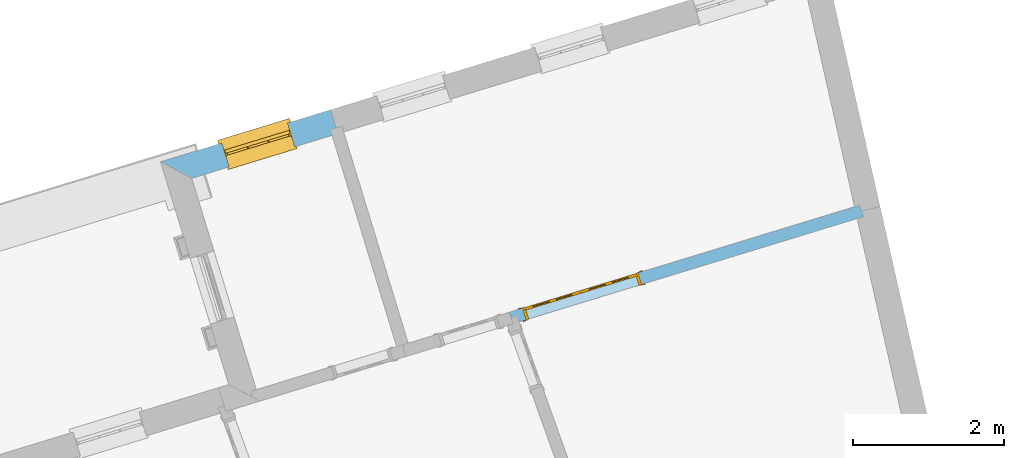
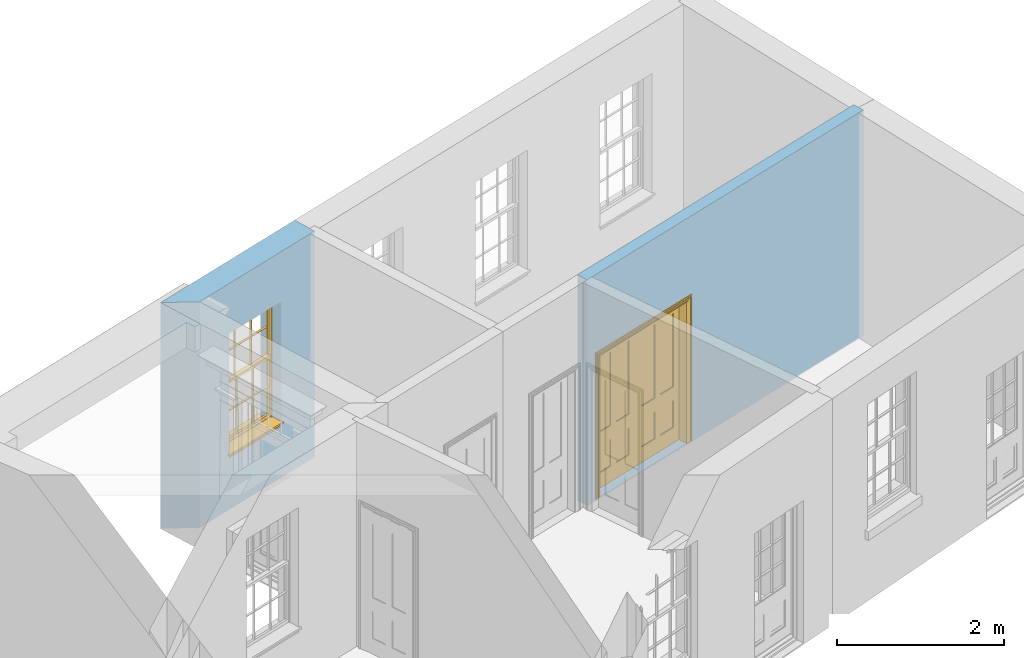
# One storey, part 8 of 10: 1 door, 1 window, 2 openings, plus 2 elements that do not belong to this part.
"""IFC2X3 building model written with IfcOpenShell, lengths in metres."""

from ifc_helpers import new_model, si_unit, frame, origin, place, context, subcontext, project, spatial, polyline, outline, extrude, faceted_brep, material, layer, layer_set, layer_usage, element, fill, save


model = new_model("IFC2X3")

# Units and contexts
model_context = context("Model", 3, world=origin())
body_context = subcontext(model_context, "Body", "Model", "MODEL_VIEW")
ifc_project = project(units=[si_unit("PLANEANGLEUNIT", "RADIAN"), si_unit("MASSUNIT", "GRAM", prefix="KILO"), si_unit("FORCEUNIT", "NEWTON", prefix="KILO"), si_unit("LENGTHUNIT", "METRE")], contexts=[model_context])

# Site, building, storey
site_placement = place(None, origin())
site = spatial("IfcSite", under=ifc_project, at=site_placement, CompositionType="ELEMENT")
building_placement = place(None, origin())
building = spatial("IfcBuilding", under=site, at=building_placement, Name="Building plot-9", CompositionType="ELEMENT")
storey_placement = place(None, frame((0.0, 0.0, 1.0)))
storey = spatial("IfcBuildingStorey", under=building, at=storey_placement, Name="Floor 0", CompositionType="ELEMENT", Elevation=1.0)

# Wall, opening, window
ifc_material_1 = material(Name="Masonry")
ifc_layer_1 = layer(ifc_material_1, 0.33, ventilated=False)
ifc_layer_set_1 = layer_set([ifc_layer_1], Name="My Wall")
ifc_layer_usage_1 = layer_usage(ifc_layer_set_1, "AXIS2", "NEGATIVE", 0.08)
wall_1_placement = place(storey_placement, origin())
wall_1 = element("IfcWallStandardCase", 1, at=wall_1_placement, inside=storey, material=ifc_layer_usage_1, Name="exterior", context=body_context, shape_type="SweptSolid", body=[
    extrude(outline(polyline([(34.0704461659636, 21.7289389517045), (33.9739704454548, 22.0445216434864), (31.7285492158165, 21.3580814912976), (32.1406076281071, 21.1389745200244), (34.0704461659636, 21.7289389517045)])), origin(), (0.0, 0.0, 1.0), 3.3),
])
opening_1_placement = place(storey_placement, frame((0.0, 0.0, 0.75)))
opening_1 = element("IfcOpeningElement", 2, at=opening_1_placement, cuts=wall_1, Name="Opening", ObjectType="Opening", context=body_context, shape_type="SweptSolid", body=[
    extrude(outline(polyline([(33.4059203192221, 21.8708649549528), (32.5356771388537, 21.6048258468833), (32.6321528593624, 21.2892431551014), (33.5023960397308, 21.5552822631709), (33.4059203192221, 21.8708649549528)])), origin(), (0.0, 0.0, 1.0), 1.82),
])
window_placement = place(storey_placement, frame((33.4790079862741, 21.6317871581483, 0.75), z_axis=(0.0, 0.0, 1.0), x_axis=(-0.870243180368334, -0.266039108069478, 0.0)))
window = element("IfcWindow", 3, at=window_placement, inside=storey, Name="circulation street window", OverallHeight=1.82, OverallWidth=0.91, context=body_context, shape_type="Brep", held_by="IfcProductRepresentation", body=[
    faceted_brep([(0.033125, -0.105, 0.975209), (0.01, -0.105, 0.975209), (0.033125, -0.105, 1.376042), (0.876875, -0.105, 0.975209), (0.876875, -0.105, 1.376042), (0.9, -0.105, 0.975209), (0.876875, -0.105, 1.386042), (0.876875, -0.105, 1.786875), (0.9, -0.105, 1.81), (0.033125, -0.105, 1.786875), (0.033125, -0.105, 1.386042), (0.01, -0.105, 1.81), (0.876875, -0.135, 1.376042), (0.876875, -0.135, 0.975209), (0.9, -0.135, 0.937083), (0.033125, -0.135, 1.786875), (0.01, -0.135, 1.81), (0.033125, -0.135, 1.386042), (0.01, -0.135, 0.937083), (0.033125, -0.135, 0.975209), (0.033125, -0.135, 1.376042), (0.876875, -0.135, 1.786875), (0.876875, -0.135, 1.386042), (0.9, -0.135, 1.81), (0.033125, -0.105, 0.937083), (0.01, -0.105, 0.937083), (0.033125, -0.105, 0.53625), (0.876875, -0.105, 0.937083), (0.876875, -0.105, 0.53625), (0.9, -0.105, 0.937083), (0.876875, -0.105, 0.52625), (0.876875, -0.105, 0.125417), (0.9, -0.105, 0.077167), (0.033125, -0.105, 0.125417), (0.033125, -0.105, 0.52625), (0.01, -0.105, 0.077167), (-0.0425, -0.25, 0.01), (-0.0425, -0.3, 0.001667), (0.0, -0.25, 0.01), (0.9525, -0.25, 0.01), (0.91, -0.25, 0.01), (0.9525, -0.3, 0.001667), (-0.02, 0.08, 0.077167), (0.0, 0.08, 0.077167), (-0.02, 0.11, 0.077167), (0.0, -0.06, 0.077167), (0.01, -0.06, 0.077167), (0.91, -0.06, 0.077167), (0.91, 0.08, 0.077167), (0.9, -0.06, 0.077167), (0.93, 0.08, 0.077167), (0.93, 0.11, 0.077167), (0.01, -0.075, 0.975209), (0.9, -0.075, 0.975209), (0.876875, -0.075, 0.125417), (0.876875, -0.075, 0.52625), (0.9, -0.075, 0.077167), (0.876875, -0.075, 0.53625), (0.876875, -0.075, 0.937083), (0.033125, -0.075, 0.125417), (0.01, -0.075, 0.077167), (0.033125, -0.075, 0.52625), (0.033125, -0.075, 0.937083), (0.033125, -0.075, 0.53625), (-0.02, 0.08, 0.052167), (-0.02, 0.11, 0.052167), (0.93, 0.11, 0.052167), (0.93, 0.08, 0.052167), (0.91, 0.08, 0.052167), (0.0, 0.08, 0.052167), (0.91, -0.15, 0.026667), (0.0, -0.15, 0.026667), (-0.0425, -0.3, -0.123333), (0.9525, -0.3, -0.123333), (-0.0425, -0.25, -0.123333), (0.9525, -0.25, -0.123333), (0.01, -0.06, 1.81), (0.9, -0.06, 1.81), (0.0, -0.06, 1.82), (0.91, -0.06, 1.82), (0.01, -0.15, 0.077167), (0.9, -0.15, 0.077167), (0.592292, -0.105, 0.125417), (0.592292, -0.075, 0.125417), (0.317708, -0.075, 0.125417), (0.317708, -0.105, 0.125417), (0.592292, -0.105, 0.53625), (0.317708, -0.105, 0.53625), (0.317708, -0.105, 0.52625), (0.592292, -0.105, 0.52625), (0.592292, -0.075, 0.53625), (0.317708, -0.075, 0.53625), (0.592292, -0.135, 1.386042), (0.592292, -0.105, 1.386042), (0.317708, -0.105, 1.386042), (0.317708, -0.135, 1.386042), (0.317708, -0.135, 1.376042), (0.592292, -0.135, 1.376042), (0.317708, -0.105, 1.376042), (0.592292, -0.105, 1.376042), (0.602292, -0.135, 1.376042), (0.592292, -0.135, 0.975209), (0.602292, -0.135, 0.975209), (0.602292, -0.105, 0.975209), (0.592292, -0.105, 0.975209), (0.602292, -0.105, 1.376042), (0.602292, -0.075, 0.53625), (0.602292, -0.105, 0.53625), (0.317708, -0.075, 0.52625), (0.307708, -0.075, 0.125417), (0.307708, -0.075, 0.52625), (0.602292, -0.075, 0.52625), (0.602292, -0.075, 0.125417), (0.592292, -0.075, 0.52625), (0.307708, -0.075, 0.53625), (0.317708, -0.075, 0.937083), (0.307708, -0.075, 0.937083), (0.602292, -0.075, 0.937083), (0.592292, -0.075, 0.937083), (0.307708, -0.105, 0.52625), (0.307708, -0.105, 0.125417), (0.307708, -0.105, 0.53625), (0.307708, -0.105, 0.937083), (0.592292, -0.105, 0.937083), (0.317708, -0.105, 0.937083), (0.602292, -0.105, 0.937083), (0.602292, -0.105, 0.52625), (0.602292, -0.105, 0.125417), (0.307708, -0.135, 1.386042), (0.307708, -0.135, 1.376042), (0.307708, -0.135, 0.975209), (0.317708, -0.135, 0.975209), (0.317708, -0.135, 1.786875), (0.307708, -0.135, 1.786875), (0.602292, -0.135, 1.786875), (0.592292, -0.135, 1.786875), (0.602292, -0.135, 1.386042), (0.602292, -0.105, 1.386042), (0.307708, -0.105, 1.386042), (0.307708, -0.105, 1.786875), (0.317708, -0.105, 1.786875), (0.592292, -0.105, 1.786875), (0.602292, -0.105, 1.786875), (0.307708, -0.105, 1.376042), (0.317708, -0.105, 0.975209), (0.307708, -0.105, 0.975209), (0.91, -0.15, 1.82), (0.9, -0.15, 1.81), (0.01, -0.15, 1.81), (0.0, -0.15, 1.82), (0.91, -0.25, 0.0), (0.0, -0.25, 0.0), (0.91, 0.08, 0.0), (0.0, 0.08, 0.0)], [[[0, 1, 2]], [[3, 4, 5]], [[6, 7, 8]], [[9, 10, 11]], [[12, 13, 14]], [[15, 16, 17]], [[18, 19, 20]], [[21, 22, 23]], [[24, 25, 26]], [[27, 28, 29]], [[30, 31, 32]], [[33, 34, 35]], [[14, 27, 29]], [[25, 24, 18]], [[36, 37, 38]], [[39, 40, 41]], [[42, 43, 44]], [[45, 46, 43]], [[47, 48, 49]], [[50, 51, 48]], [[1, 0, 52]], [[5, 53, 3]], [[54, 55, 56]], [[57, 58, 53]], [[59, 60, 61]], [[62, 63, 52]], [[48, 43, 46, 49]], [[51, 44, 43, 48]], [[64, 42, 44, 65]], [[65, 44, 51, 66]], [[66, 51, 50, 67]], [[65, 66, 68, 69]], [[60, 56, 49, 46]], [[70, 71, 38, 40]], [[37, 41, 40, 38]], [[37, 72, 73, 41]], [[74, 75, 73, 72]], [[8, 11, 76, 77]], [[76, 78, 79, 77]], [[32, 35, 80, 81]], [[81, 80, 71, 70]], [[82, 83, 84, 85]], [[86, 87, 88, 89]], [[86, 90, 91, 87]], [[92, 93, 94, 95]], [[92, 95, 96, 97]], [[96, 98, 99, 97]], [[100, 97, 101, 102]], [[103, 104, 99, 105]], [[97, 99, 104, 101]], [[102, 103, 105, 100]], [[28, 57, 106, 107]], [[108, 84, 109, 110]], [[111, 112, 83, 113]], [[114, 110, 61, 63]], [[90, 113, 108, 91]], [[115, 91, 114, 116]], [[117, 106, 90, 118]], [[111, 106, 57, 55]], [[119, 110, 109, 120]], [[34, 61, 110, 119]], [[89, 113, 83, 82]], [[88, 108, 113, 89]], [[85, 84, 108, 88]], [[121, 114, 63, 26]], [[122, 116, 114, 121]], [[123, 118, 90, 86]], [[87, 91, 115, 124]], [[107, 106, 117, 125]], [[126, 111, 55, 30]], [[127, 112, 111, 126]], [[126, 30, 28, 107]], [[88, 119, 120, 85]], [[126, 89, 82, 127]], [[125, 123, 86, 107]], [[121, 26, 34, 119]], [[124, 122, 121, 87]], [[128, 17, 20, 129]], [[96, 129, 130, 131]], [[132, 133, 128, 95]], [[134, 135, 92, 136]], [[100, 12, 22, 136]], [[137, 6, 4, 105]], [[94, 138, 139, 140]], [[137, 93, 141, 142]], [[99, 98, 94, 93]], [[143, 2, 10, 138]], [[144, 145, 143, 98]], [[129, 143, 145, 130]], [[20, 2, 143, 129]], [[131, 144, 98, 96]], [[128, 138, 10, 17]], [[133, 139, 138, 128]], [[135, 141, 93, 92]], [[95, 94, 140, 132]], [[22, 6, 137, 136]], [[136, 137, 142, 134]], [[100, 105, 4, 12]], [[107, 86, 89, 126]], [[106, 111, 113, 90]], [[91, 108, 110, 114]], [[87, 121, 119, 88]], [[97, 100, 136, 92]], [[129, 96, 95, 128]], [[98, 143, 138, 94]], [[105, 99, 93, 137]], [[131, 101, 104, 144]], [[124, 115, 118, 123]], [[132, 140, 141, 135]], [[120, 109, 59, 33]], [[15, 9, 139, 133]], [[134, 142, 7, 21]], [[31, 54, 112, 127]], [[36, 74, 72, 37]], [[39, 41, 73, 75]], [[18, 14, 101, 131]], [[23, 16, 132, 135]], [[83, 56, 60, 84]], [[52, 53, 118, 115]], [[53, 52, 144, 104]], [[11, 8, 141, 140]], [[14, 18, 124, 123]], [[2, 1, 11, 10]], [[8, 5, 4, 6]], [[57, 53, 56, 55]], [[60, 52, 63, 61]], [[26, 25, 35, 34]], [[32, 29, 28, 30]], [[14, 23, 22, 12]], [[18, 20, 17, 16]], [[19, 0, 2, 20]], [[17, 10, 9, 15]], [[12, 4, 3, 13]], [[21, 7, 6, 22]], [[27, 58, 57, 28]], [[30, 55, 54, 31]], [[33, 59, 61, 34]], [[26, 63, 62, 24]], [[5, 8, 77, 53]], [[76, 11, 1, 52]], [[46, 45, 78, 76]], [[49, 77, 79, 47]], [[70, 146, 147, 81]], [[71, 80, 148, 149]], [[19, 130, 145, 0]], [[102, 13, 3, 103]], [[116, 122, 24, 62]], [[29, 32, 81, 14]], [[80, 35, 25, 18]], [[60, 46, 76, 52]], [[77, 49, 56, 53]], [[23, 14, 81, 147]], [[16, 148, 80, 18]], [[35, 85, 120]], [[120, 33, 35]], [[127, 82, 32]], [[32, 31, 127]], [[32, 82, 85, 35]], [[102, 101, 14]], [[14, 13, 102]], [[18, 131, 130]], [[130, 19, 18]], [[134, 21, 23]], [[23, 135, 134]], [[16, 15, 133]], [[133, 132, 16]], [[11, 140, 139]], [[139, 9, 11]], [[142, 141, 8]], [[8, 7, 142]], [[23, 147, 148, 16]], [[146, 149, 148, 147]], [[52, 115, 116]], [[116, 62, 52]], [[118, 53, 117]], [[58, 117, 53]], [[27, 125, 117, 58]], [[56, 83, 112]], [[112, 54, 56]], [[109, 84, 60]], [[60, 59, 109]], [[125, 27, 14]], [[14, 123, 125]], [[122, 124, 18]], [[18, 24, 122]], [[145, 144, 52]], [[52, 0, 145]], [[103, 3, 53]], [[53, 104, 103]], [[79, 78, 149, 146]], [[78, 45, 71, 149]], [[146, 70, 47, 79]], [[150, 75, 74, 151]], [[68, 66, 67]], [[48, 68, 67, 50]], [[69, 64, 65]], [[42, 64, 69, 43]], [[69, 68, 152, 153]], [[70, 68, 48, 47]], [[150, 152, 68, 70]], [[43, 69, 71, 45]], [[69, 153, 151, 71]], [[152, 150, 151, 153]], [[38, 151, 74, 36]], [[71, 151, 38]], [[39, 75, 150, 40]], [[40, 150, 70]]]),
])
fill(opening_1, window)

# Wall, opening, door
ifc_material_2 = material(Name="Masonry")
ifc_layer_2 = layer(ifc_material_2, 0.16, ventilated=False)
ifc_layer_set_2 = layer_set([ifc_layer_2], Name="My Wall")
ifc_layer_usage_2 = layer_usage(ifc_layer_set_2, "AXIS2", "NEGATIVE", 0.08)
wall_2_placement = place(storey_placement, origin())
wall_2 = element("IfcWallStandardCase", 4, at=wall_2_placement, inside=storey, material=ifc_layer_usage_2, Name="interior", context=body_context, shape_type="SweptSolid", body=[
    extrude(outline(polyline([(36.3355604715048, 19.3699546633605), (36.3823365784182, 19.2169448734057), (41.0127738898931, 20.6325002493123), (40.9659977829797, 20.7855100392671), (36.3355604715048, 19.3699546633605)])), origin(), (0.0, 0.0, 1.0), 3.3),
])
opening_2_placement = place(storey_placement, frame((0.0, 0.0, 0.02)))
opening_2 = element("IfcOpeningElement", 5, at=opening_2_placement, cuts=wall_2, Name="Opening", ObjectType="Opening", context=body_context, shape_type="SweptSolid", body=[
    extrude(outline(polyline([(36.5544725921174, 19.2695679936831), (38.0845704916661, 19.7373290628163), (38.0377943847528, 19.8903388527712), (36.5076964852041, 19.422577783638), (36.5544725921174, 19.2695679936831)])), origin(), (0.0, 0.0, 1.0), 2.1),
])
door_placement = place(storey_placement, frame((36.5310845386607, 19.3460728886606, 0.02), z_axis=(0.0, 0.0, 1.0), x_axis=(1.53009789954872, 0.467761069133164, 0.0)))
door = element("IfcDoor", 6, at=door_placement, inside=storey, Name="kitchen living inside door", OverallHeight=2.1, OverallWidth=1.6, context=body_context, shape_type="Brep", held_by="IfcProductRepresentation", body=[
    faceted_brep([(0.14, 0.057, 1.895), (0.14, 0.057, 0.82), (0.363, 0.057, 0.82), (0.363, 0.057, 1.895), (0.14, 0.042, 1.895), (0.14, 0.042, 0.82), (0.363, 0.042, 0.82), (0.363, 0.042, 1.895), (0.027, 0.042, 1.895), (0.027, 0.042, 0.82), (0.363, 0.042, 0.62), (0.14, 0.042, 0.62), (0.463, 0.042, 0.82), (0.463, 0.042, 1.895), (0.363, 0.042, 2.073), (0.14, 0.042, 2.073), (0.027, 0.042, 2.073), (0.027, 0.08, 1.895), (0.027, 0.08, 0.82), (0.027, 0.042, 0.62), (0.463, 0.042, 0.62), (0.14, 0.057, 0.62), (0.363, 0.057, 0.62), (0.463, 0.057, 0.82), (0.463, 0.057, 1.895), (0.463, 0.042, 2.073), (0.14, 0.08, 2.073), (0.363, 0.08, 2.073), (0.027, 0.08, 2.073), (0.14, 0.08, 1.895), (0.14, 0.08, 0.82), (0.027, 0.08, 0.62), (0.027, 0.042, 0.225), (0.14, 0.042, 0.225), (0.363, 0.042, 0.225), (0.463, 0.042, 0.225), (0.686, 0.042, 0.62), (0.686, 0.042, 0.82), (0.14, 0.057, 0.225), (0.363, 0.057, 0.225), (0.686, 0.057, 0.82), (0.686, 0.057, 1.895), (0.686, 0.042, 1.895), (0.686, 0.042, 2.073), (0.463, 0.08, 2.073), (0.363, 0.08, 1.895), (0.14, 0.065, 1.895), (0.14, 0.065, 0.82), (0.14, 0.08, 0.62), (0.027, 0.08, 0.225), (0.027, 0.042, 0.0), (0.14, 0.042, 0.0), (0.363, 0.042, 0.0), (0.463, 0.042, 0.0), (0.463, 0.057, 0.225), (0.463, 0.057, 0.62), (0.686, 0.057, 0.62), (0.799, 0.042, 0.62), (0.799, 0.042, 0.82), (0.799, 0.042, 1.895), (0.799, 0.042, 2.073), (0.686, 0.08, 2.073), (0.463, 0.08, 1.895), (0.363, 0.065, 1.895), (0.363, 0.065, 0.82), (0.363, 0.08, 0.82), (0.363, 0.08, 0.62), (0.14, 0.08, 0.225), (0.027, 0.08, 0.0), (0.14, 0.08, 0.0), (0.363, 0.08, 0.0), (0.463, 0.08, 0.0), (0.686, 0.042, 0.0), (0.686, 0.042, 0.225), (0.686, 0.057, 0.225), (0.799, 0.042, 0.225), (0.799, 0.08, 0.62), (0.799, 0.08, 0.82), (0.799, 0.08, 1.895), (0.799, 0.08, 2.073), (0.686, 0.08, 1.895), (0.463, 0.08, 0.82), (0.463, 0.08, 0.62), (0.363, 0.065, 0.62), (0.14, 0.065, 0.62), (0.14, 0.065, 0.225), (0.363, 0.08, 0.225), (0.463, 0.08, 0.225), (0.686, 0.08, 0.0), (0.799, 0.042, 0.0), (0.799, 0.08, 0.225), (0.686, 0.08, 0.62), (0.686, 0.08, 0.82), (0.686, 0.065, 1.895), (0.463, 0.065, 1.895), (0.463, 0.065, 0.82), (0.363, 0.065, 0.225), (0.686, 0.08, 0.225), (0.799, 0.08, 0.0), (0.686, 0.065, 0.82), (0.463, 0.065, 0.62), (0.463, 0.065, 0.225), (0.686, 0.065, 0.62), (0.686, 0.065, 0.225), (1.46, 0.08, 1.895), (1.237, 0.08, 1.895), (1.237, 0.08, 2.073), (1.46, 0.08, 2.073), (1.46, 0.065, 1.895), (1.237, 0.065, 1.895), (1.137, 0.08, 1.895), (1.137, 0.08, 2.073), (1.237, 0.042, 2.073), (1.46, 0.042, 2.073), (1.573, 0.08, 1.895), (1.573, 0.08, 2.073), (1.46, 0.08, 0.82), (1.46, 0.065, 0.82), (1.237, 0.065, 0.82), (1.237, 0.08, 0.82), (1.137, 0.08, 0.82), (0.914, 0.08, 2.073), (0.914, 0.08, 1.895), (1.137, 0.042, 2.073), (1.237, 0.042, 1.895), (1.46, 0.042, 1.895), (1.573, 0.042, 2.073), (1.573, 0.08, 0.82), (1.573, 0.042, 1.895), (1.237, 0.08, 0.62), (1.137, 0.08, 0.62), (1.137, 0.065, 0.82), (1.137, 0.065, 1.895), (0.914, 0.042, 2.073), (0.914, 0.065, 1.895), (0.801, 0.08, 2.073), (0.801, 0.08, 1.895), (1.137, 0.042, 1.895), (1.237, 0.057, 1.895), (1.46, 0.057, 1.895), (1.573, 0.042, 0.82), (1.573, 0.08, 0.62), (1.46, 0.08, 0.62), (1.237, 0.08, 0.225), (1.137, 0.08, 0.225), (0.914, 0.08, 0.82), (0.914, 0.08, 0.62), (0.914, 0.065, 0.82), (0.801, 0.042, 2.073), (0.914, 0.042, 1.895), (0.801, 0.08, 0.82), (0.801, 0.042, 1.895), (1.137, 0.042, 0.82), (1.237, 0.042, 0.82), (1.237, 0.057, 0.82), (1.46, 0.057, 0.82), (1.46, 0.042, 0.82), (1.573, 0.042, 0.62), (1.573, 0.08, 0.225), (1.46, 0.08, 0.225), (1.46, 0.065, 0.62), (1.237, 0.065, 0.62), (1.237, 0.08, 0.0), (1.137, 0.08, 0.0), (1.137, 0.065, 0.225), (1.137, 0.065, 0.62), (1.237, 0.065, 0.225), (0.914, 0.065, 0.62), (0.801, 0.08, 0.62), (0.914, 0.057, 1.895), (1.137, 0.057, 1.895), (0.801, 0.042, 0.82), (1.137, 0.042, 0.62), (1.237, 0.042, 0.62), (1.137, 0.057, 0.82), (1.46, 0.042, 0.62), (1.573, 0.042, 0.225), (1.573, 0.08, 0.0), (1.46, 0.08, 0.0), (1.46, 0.065, 0.225), (1.237, 0.042, 0.0), (1.137, 0.042, 0.0), (0.914, 0.08, 0.225), (0.914, 0.08, 0.0), (0.914, 0.065, 0.225), (0.801, 0.08, 0.225), (0.801, 0.042, 0.62), (0.914, 0.042, 0.82), (0.914, 0.057, 0.82), (1.137, 0.042, 0.225), (1.237, 0.042, 0.225), (0.914, 0.042, 0.62), (1.46, 0.042, 0.225), (1.573, 0.042, 0.0), (1.46, 0.042, 0.0), (0.914, 0.042, 0.0), (0.801, 0.08, 0.0), (0.801, 0.042, 0.225), (1.237, 0.057, 0.225), (1.237, 0.057, 0.62), (1.137, 0.057, 0.62), (1.137, 0.057, 0.225), (1.46, 0.057, 0.62), (0.914, 0.057, 0.62), (1.46, 0.057, 0.225), (0.914, 0.042, 0.225), (0.801, 0.042, 0.0), (0.914, 0.057, 0.225), (0.02, 0.085, 0.0), (0.005, 0.09, 0.0), (0.005, 0.09, 2.095), (0.02, 0.085, 2.08), (0.02, 0.08, 0.0), (0.0, 0.085, 0.0), (0.0, 0.085, 2.1), (1.595, 0.09, 2.095), (1.58, 0.085, 2.08), (0.02, 0.08, 2.08), (0.0, 0.08, 0.0), (-0.032, 0.095, 0.0), (-0.032, 0.095, 2.132), (1.6, 0.085, 2.1), (1.595, 0.09, 0.0), (1.58, 0.085, 0.0), (1.58, 0.08, 2.08), (0.025, 0.08, 0.0), (0.025, 0.08, 2.075), (-0.04, 0.09, 0.0), (0.025, 0.04, 0.0), (0.0, -0.08, 0.0), (-0.04, 0.09, 2.14), (1.632, 0.095, 2.132), (1.6, 0.085, 0.0), (1.58, 0.08, 0.0), (1.575, 0.08, 2.075), (0.025, 0.04, 2.075), (-0.06, 0.08, 0.0), (0.035, -0.08, 0.0), (0.0, -0.08, 2.1), (0.0, 0.08, 2.1), (-0.04, 0.095, 0.0), (-0.04, 0.095, 2.14), (1.64, 0.09, 2.14), (1.632, 0.095, 0.0), (1.6, 0.08, 0.0), (1.575, 0.08, 0.0), (1.575, 0.04, 2.075), (0.04, 0.04, 0.0), (0.04, 0.04, 2.06), (-0.06, 0.095, 0.0), (-0.06, 0.08, 2.16), (0.015, -0.085, 0.0), (0.04, -0.08, 0.0), (-0.045, -0.08, 2.145), (-0.045, -0.08, 0.0), (1.6, -0.08, 2.1), (1.6, 0.08, 2.1), (-0.06, 0.095, 2.16), (1.64, 0.095, 2.14), (1.64, 0.09, 0.0), (1.6, -0.08, 0.0), (1.575, 0.04, 0.0), (1.56, 0.04, 2.06), (0.04, -0.08, 2.06), (1.66, 0.08, 2.16), (-0.017, -0.095, 0.0), (-0.025, -0.09, 0.0), (0.02, -0.09, 0.0), (0.035, -0.085, 0.0), (0.035, -0.08, 2.065), (1.645, -0.08, 2.145), (-0.045, -0.095, 2.145), (-0.045, -0.095, 0.0), (1.66, 0.095, 2.16), (1.64, 0.095, 0.0), (1.66, 0.08, 0.0), (1.565, -0.08, 0.0), (1.56, 0.04, 0.0), (1.56, -0.08, 2.06), (-0.017, -0.095, 2.117), (-0.025, -0.09, 2.125), (0.015, -0.085, 2.085), (0.02, -0.09, 2.08), (0.035, -0.085, 2.065), (1.565, -0.08, 2.065), (1.645, -0.08, 0.0), (1.645, -0.095, 2.145), (-0.025, -0.095, 0.0), (1.66, 0.095, 0.0), (1.585, -0.085, 0.0), (1.56, -0.08, 0.0), (1.617, -0.095, 2.117), (1.625, -0.09, 2.125), (-0.025, -0.095, 2.125), (1.585, -0.085, 2.085), (1.58, -0.09, 2.08), (1.565, -0.085, 2.065), (1.625, -0.09, 0.0), (1.645, -0.095, 0.0), (1.625, -0.095, 2.125), (1.617, -0.095, 0.0), (1.565, -0.085, 0.0), (1.58, -0.09, 0.0), (1.625, -0.095, 0.0)], [[[0, 1, 2, 3]], [[1, 0, 4, 5]], [[2, 1, 5, 6]], [[6, 7, 3, 2]], [[7, 4, 0, 3]], [[4, 8, 9, 5]], [[10, 6, 5, 11]], [[6, 12, 13, 7]], [[14, 15, 4, 7]], [[15, 16, 8, 4]], [[9, 8, 17, 18]], [[5, 9, 19, 11]], [[10, 20, 12, 6]], [[10, 11, 21, 22]], [[13, 12, 23, 24]], [[7, 13, 25, 14]], [[26, 15, 14, 27]], [[28, 16, 15, 26]], [[8, 16, 28, 17]], [[17, 29, 30, 18]], [[18, 31, 19, 9]], [[11, 19, 32, 33]], [[34, 35, 20, 10]], [[20, 36, 37, 12]], [[11, 33, 38, 21]], [[39, 22, 21, 38]], [[34, 10, 22, 39]], [[12, 37, 40, 23]], [[24, 23, 40, 41]], [[42, 13, 24, 41]], [[13, 42, 43, 25]], [[14, 25, 44, 27]], [[26, 27, 45, 29]], [[28, 26, 29, 17]], [[30, 29, 46, 47]], [[18, 30, 48, 31]], [[31, 49, 32, 19]], [[33, 32, 50, 51]], [[52, 53, 35, 34]], [[20, 35, 54, 55]], [[36, 20, 55, 56]], [[36, 57, 58, 37]], [[33, 34, 39, 38]], [[37, 42, 41, 40]], [[42, 59, 60, 43]], [[44, 25, 43, 61]], [[62, 45, 27, 44]], [[29, 45, 63, 46]], [[46, 63, 64, 47]], [[65, 30, 47, 64]], [[30, 65, 66, 48]], [[31, 48, 67, 49]], [[68, 50, 32, 49]], [[68, 69, 51, 50]], [[34, 33, 51, 52]], [[53, 52, 70, 71]], [[53, 72, 73, 35]], [[35, 73, 74, 54]], [[55, 54, 74, 56]], [[73, 36, 56, 74]], [[73, 75, 57, 36]], [[57, 76, 77, 58]], [[37, 58, 59, 42]], [[78, 79, 60, 59]], [[60, 79, 61, 43]], [[80, 62, 44, 61]], [[81, 65, 45, 62]], [[45, 65, 64, 63]], [[82, 66, 65, 81]], [[48, 66, 83, 84]], [[67, 48, 84, 85]], [[49, 67, 69, 68]], [[52, 51, 69, 70]], [[71, 70, 86, 87]], [[72, 53, 71, 88]], [[72, 89, 75, 73]], [[75, 90, 76, 57]], [[76, 91, 92, 77]], [[78, 59, 58, 77]], [[78, 80, 61, 79]], [[62, 80, 93, 94]], [[81, 62, 94, 95]], [[87, 86, 66, 82]], [[91, 82, 81, 92]], [[66, 86, 96, 83]], [[84, 83, 96, 85]], [[86, 67, 85, 96]], [[67, 86, 70, 69]], [[88, 71, 87, 97]], [[89, 72, 88, 98]], [[89, 98, 90, 75]], [[90, 97, 91, 76]], [[80, 78, 77, 92]], [[80, 92, 99, 93]], [[99, 95, 94, 93]], [[92, 81, 95, 99]], [[87, 82, 100, 101]], [[82, 91, 102, 100]], [[97, 87, 101, 103]], [[98, 88, 97, 90]], [[91, 97, 103, 102]], [[103, 101, 100, 102]], [[104, 105, 106, 107]], [[105, 104, 108, 109]], [[105, 110, 111, 106]], [[106, 112, 113, 107]], [[114, 104, 107, 115]], [[104, 116, 117, 108]], [[117, 118, 109, 108]], [[119, 105, 109, 118]], [[119, 120, 110, 105]], [[121, 111, 110, 122]], [[123, 112, 106, 111]], [[124, 125, 113, 112]], [[126, 115, 107, 113]], [[104, 114, 127, 116]], [[114, 115, 126, 128]], [[116, 119, 118, 117]], [[129, 130, 120, 119]], [[110, 120, 131, 132]], [[121, 133, 123, 111]], [[122, 110, 132, 134]], [[135, 121, 122, 136]], [[137, 124, 112, 123]], [[125, 124, 138, 139]], [[125, 128, 126, 113]], [[114, 128, 140, 127]], [[141, 142, 116, 127]], [[142, 129, 119, 116]], [[143, 144, 130, 129]], [[145, 120, 130, 146]], [[120, 145, 147, 131]], [[134, 132, 131, 147]], [[135, 148, 133, 121]], [[123, 133, 149, 137]], [[145, 122, 134, 147]], [[136, 122, 145, 150]], [[151, 148, 135, 136]], [[152, 153, 124, 137]], [[124, 153, 154, 138]], [[138, 154, 155, 139]], [[156, 125, 139, 155]], [[156, 140, 128, 125]], [[157, 141, 127, 140]], [[158, 159, 142, 141]], [[129, 142, 160, 161]], [[162, 163, 144, 143]], [[130, 144, 164, 165]], [[143, 129, 161, 166]], [[146, 130, 165, 167]], [[150, 145, 146, 168]], [[133, 148, 151, 149]], [[137, 149, 169, 170]], [[171, 151, 136, 150]], [[172, 173, 153, 152]], [[152, 137, 170, 174]], [[153, 156, 155, 154]], [[175, 157, 140, 156]], [[176, 158, 141, 157]], [[177, 178, 159, 158]], [[142, 159, 179, 160]], [[179, 166, 161, 160]], [[180, 181, 163, 162]], [[182, 144, 163, 183]], [[178, 162, 143, 159]], [[144, 182, 184, 164]], [[167, 165, 164, 184]], [[159, 143, 166, 179]], [[182, 146, 167, 184]], [[168, 146, 182, 185]], [[150, 168, 186, 171]], [[149, 151, 171, 187]], [[149, 187, 188, 169]], [[169, 188, 174, 170]], [[189, 190, 173, 172]], [[173, 175, 156, 153]], [[172, 152, 187, 191]], [[187, 152, 174, 188]], [[192, 176, 157, 175]], [[193, 177, 158, 176]], [[193, 194, 178, 177]], [[181, 180, 190, 189]], [[181, 195, 183, 163]], [[194, 180, 162, 178]], [[185, 182, 183, 196]], [[168, 185, 197, 186]], [[187, 171, 186, 191]], [[173, 190, 198, 199]], [[189, 172, 200, 201]], [[175, 173, 199, 202]], [[172, 191, 203, 200]], [[194, 193, 176, 192]], [[192, 175, 202, 204]], [[180, 194, 192, 190]], [[189, 205, 195, 181]], [[196, 183, 195, 206]], [[196, 206, 197, 185]], [[191, 186, 197, 205]], [[190, 192, 204, 198]], [[199, 198, 204, 202]], [[201, 200, 203, 207]], [[205, 189, 201, 207]], [[191, 205, 207, 203]], [[205, 197, 206, 195]], [[208, 209, 210, 211]], [[208, 212, 213, 209]], [[209, 213, 214, 210]], [[211, 210, 215, 216]], [[211, 217, 212, 208]], [[218, 213, 212]], [[213, 219, 220, 214]], [[210, 214, 221, 215]], [[216, 215, 222, 223]], [[217, 211, 216, 224]], [[225, 212, 217, 226]], [[219, 213, 218, 227]], [[218, 212, 228, 229]], [[219, 227, 230, 220]], [[214, 220, 231, 221]], [[215, 221, 232, 222]], [[222, 232, 233, 223]], [[224, 216, 223, 233]], [[226, 217, 224, 234]], [[225, 228, 212]], [[235, 228, 225, 226]], [[236, 227, 218]], [[237, 229, 228]], [[229, 238, 239, 218]], [[227, 240, 241, 230]], [[220, 230, 242, 231]], [[221, 231, 243, 232]], [[244, 233, 232]], [[234, 224, 233, 245]], [[246, 235, 226, 234]], [[247, 228, 235, 248]], [[240, 227, 236, 249]], [[239, 250, 236, 218]], [[251, 229, 237]], [[252, 237, 228, 247]], [[253, 238, 229, 254]], [[238, 255, 256, 239]], [[241, 240, 257]], [[230, 241, 258, 242]], [[231, 242, 259, 243]], [[259, 244, 232, 243]], [[260, 261, 233, 244]], [[245, 233, 261]], [[261, 246, 234, 245]], [[248, 235, 246, 262]], [[248, 263, 252, 247]], [[250, 257, 249, 236]], [[240, 249, 257]], [[256, 264, 250, 239]], [[265, 266, 229, 251]], [[267, 251, 237, 268]], [[263, 269, 237, 252]], [[270, 255, 238, 253]], [[229, 266, 254]], [[271, 253, 254, 272]], [[256, 255, 260, 244]], [[273, 241, 257]], [[273, 258, 241]], [[242, 258, 274, 259]], [[275, 244, 259]], [[260, 276, 261]], [[261, 277, 262, 246]], [[262, 278, 263, 248]], [[264, 273, 257, 250]], [[244, 275, 264, 256]], [[266, 265, 279, 280]], [[265, 251, 281, 279]], [[251, 267, 282, 281]], [[269, 283, 268, 237]], [[267, 268, 283, 282]], [[278, 284, 269, 263]], [[285, 260, 255, 270]], [[286, 270, 253, 271]], [[272, 254, 266, 287]], [[271, 272, 287]], [[273, 274, 258]], [[288, 275, 259, 274]], [[276, 260, 289]], [[277, 261, 276, 290]], [[278, 262, 277, 290]], [[275, 288, 273, 264]], [[280, 279, 291, 292]], [[287, 266, 280, 293]], [[279, 281, 294, 291]], [[281, 282, 295, 294]], [[284, 296, 283, 269]], [[282, 283, 296, 295]], [[290, 276, 284, 278]], [[285, 297, 260]], [[298, 285, 270, 286]], [[299, 286, 271]], [[271, 287, 293]], [[273, 288, 274]], [[300, 289, 260, 297]], [[301, 276, 289, 302]], [[292, 291, 300, 297]], [[293, 280, 292, 299]], [[291, 294, 289, 300]], [[294, 295, 302, 289]], [[296, 284, 276, 301]], [[295, 296, 301, 302]], [[303, 297, 285, 298]], [[299, 298, 286]], [[271, 293, 299]], [[299, 292, 297, 303]], [[299, 303, 298]]]),
])
fill(opening_2, door)

save(model, "model.ifc")
